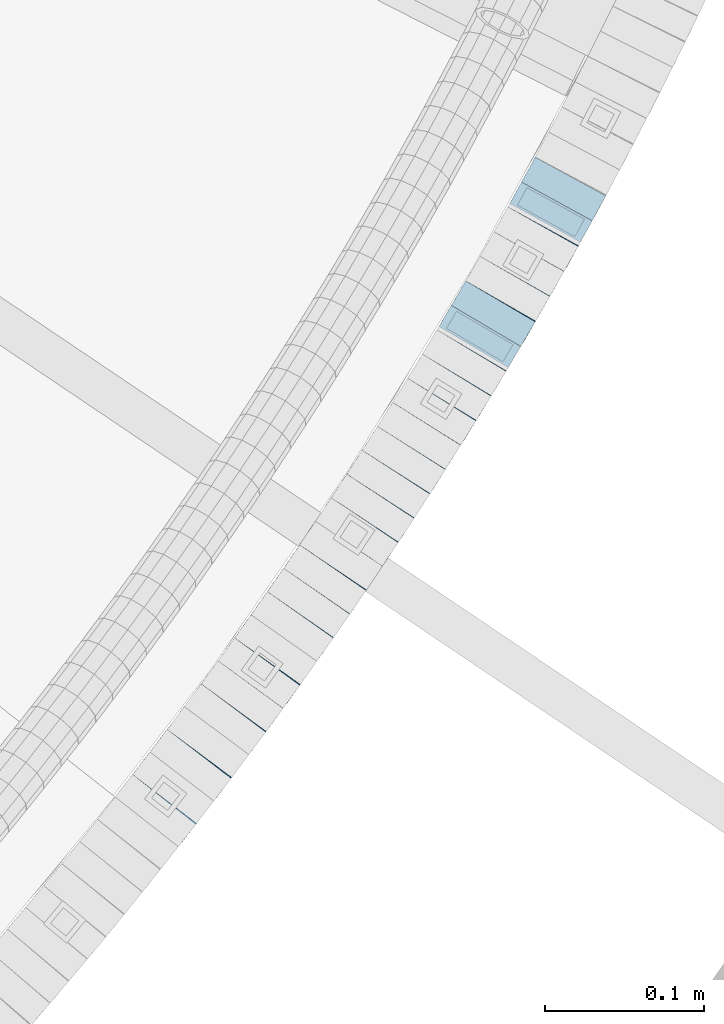
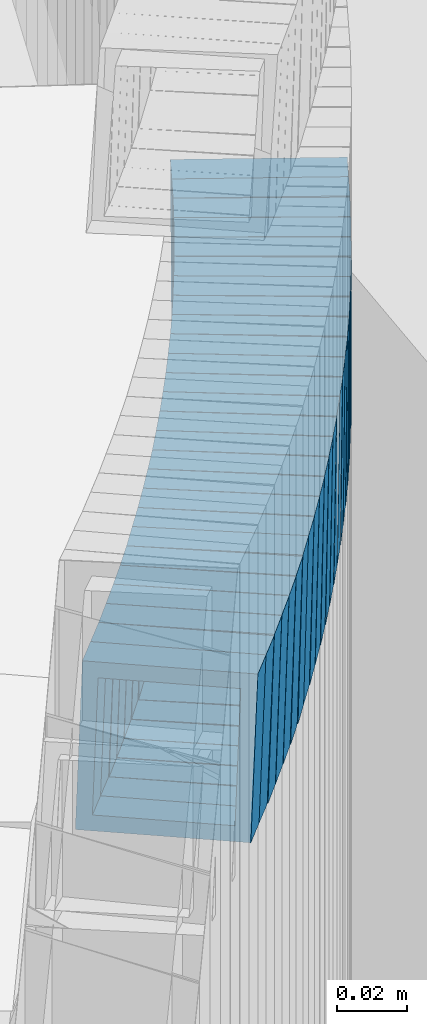
# One storey, part 778 of 975: 26 beams.
"""IFC2X3 building model written with IfcOpenShell, lengths in millimetres."""

from ifc_helpers import new_model, si_unit, frame, origin_with_axes, place, context, subcontext, project, spatial, faceted_brep, material, type_object, element, save


model = new_model("IFC2X3")

# Units and contexts
model_context = context("Model", 3, precision=1e-05, world=origin_with_axes())
body_context = subcontext(model_context, "Body", "Model", "MODEL_VIEW")
ifc_project = project(units=[si_unit("LENGTHUNIT", "METRE", prefix="MILLI"), si_unit("AREAUNIT", "SQUARE_METRE"), si_unit("VOLUMEUNIT", "CUBIC_METRE"), si_unit("MASSUNIT", "GRAM", prefix="KILO"), si_unit("TIMEUNIT", "SECOND"), si_unit("PLANEANGLEUNIT", "RADIAN"), si_unit("SOLIDANGLEUNIT", "STERADIAN"), si_unit("THERMODYNAMICTEMPERATUREUNIT", "DEGREE_CELSIUS"), si_unit("LUMINOUSINTENSITYUNIT", "LUMEN")], contexts=[model_context])

# Site, building, storey
site_placement = place(None, origin_with_axes())
site = spatial("IfcSite", under=ifc_project, at=site_placement, CompositionType="ELEMENT")
building_placement = place(site_placement, origin_with_axes())
building = spatial("IfcBuilding", under=site, at=building_placement, Name="Undefined", CompositionType="ELEMENT")
storey_placement = place(building_placement, origin_with_axes())
storey = spatial("IfcBuildingStorey", under=building, at=storey_placement, Name="Undefined", CompositionType="ELEMENT", Elevation=0.0)

# Beams
ifc_material = material()
beam_type = type_object("IfcBeamType", Name="HSS2X2X.188_TUBES", PredefinedType="NOTDEFINED")
for number, where, z_axis, x_axis, name in (
    (1, (36998.4211909885, 1638.69468786156, 2459.19732250594), (-0.793246576330857, 0.608900541253967, 0.0), (0.58019777288617, 0.755853978851687, -0.303406174940462), "WALL"),
    (2, (37009.3211909885, 1652.89468786156, 2453.49732250594), (-0.793246576330857, 0.608900541253967, 0.0), (0.58019777288617, 0.755853978851687, -0.303406174940462), "WALL"),
):
    element("IfcBeam", number, at=place(storey_placement, frame(where, z_axis=z_axis, x_axis=x_axis)), inside=storey, type_object=beam_type, material=ifc_material, Name=name, ObjectType="HSS2X2X.188_TUBES", context=body_context, shape_type="Brep", body=[
        faceted_brep([(0.0, 20.6374999999753, -20.6375000000298), (0.0, -20.6375000000153, -20.6375000000153), (18.7853666454903, -20.6375000000535, -20.6375000000326), (18.785366645363, 20.6374999999862, -20.6375000000044), (0.0, -20.6374999999825, 20.6375000000335), (18.785366645352, -20.6375000000007, 20.6374999999989), (0.0, 20.6375000000116, 20.6375000000189), (18.7853666453102, 20.6375000000025, 20.6374999999753), (0.0, 25.3999999999724, -25.4000000000342), (0.0, 25.400000000016, 25.4000000000196), (18.7853666452065, 25.4000000000451, 25.4000000000351), (18.7853666453739, 25.3999999999833, -25.400000000006), (0.0, -25.399999999976, 25.4000000000378), (18.7853666497213, -25.399999993424, 25.3999999995158), (0.0, -25.400000000016, -25.4000000000196), (18.7853666455194, -25.4000000000633, -25.4000000000406)], [[[0, 1, 2, 3]], [[1, 4, 5, 2]], [[4, 6, 7, 5]], [[6, 0, 3, 7]], [[8, 9, 10, 11]], [[9, 12, 13, 10]], [[12, 14, 15, 13]], [[14, 8, 11, 15]], [[13, 15, 11, 10], [5, 7, 3, 2]], [[14, 12, 9, 8], [6, 4, 1, 0]]]),
    ])
beam_1_placement = place(storey_placement, frame((37020.4021489882, 1667.17520577489, 2447.84194460413), z_axis=(-0.800671390520529, 0.599103767641235, 0.0), x_axis=(0.569810315255925, 0.76152219734206, -0.308869143138749)))
element("IfcBeam", 3, at=beam_1_placement, inside=storey, type_object=beam_type, material=ifc_material, Name="WALL", ObjectType="HSS2X2X.188_TUBES", context=body_context, shape_type="Brep", body=[
    faceted_brep([(0.0, 20.6374999999753, -20.6375000000298), (0.0, -20.6375000000153, -20.6375000000153), (18.7771137292038, -20.637500000008, -20.6374999999862), (18.777113729182, 20.6375000000062, -20.6375000000189), (0.0, -20.6374999999825, 20.6375000000335), (18.7771137291729, -20.6374999999916, 20.6374999999753), (0.0, 20.6375000000116, 20.6375000000189), (18.7771137291529, 20.6375000000207, 20.6374999999389), (0.0, 25.3999999999724, -25.4000000000342), (0.0, 25.400000000016, 25.4000000000196), (18.7771137291475, 25.4000000000251, 25.3999999999287), (18.7771137291857, 25.4000000000051, -25.4000000000196), (0.0, -25.399999999976, 25.4000000000378), (18.7771137291711, -25.3999999999905, 25.3999999999724), (0.0, -25.400000000016, -25.4000000000196), (18.7771137292129, -25.4000000000124, -25.3999999999724)], [[[0, 1, 2, 3]], [[1, 4, 5, 2]], [[4, 6, 7, 5]], [[6, 0, 3, 7]], [[8, 9, 10, 11]], [[9, 12, 13, 10]], [[12, 14, 15, 13]], [[14, 8, 11, 15]], [[13, 15, 11, 10], [5, 7, 3, 2]], [[14, 12, 9, 8], [6, 4, 1, 0]]]),
])
beam_2_placement = place(storey_placement, frame((37031.2657047011, 1681.65115418061, 2441.99247534744), z_axis=(-0.802667604861859, 0.596426622565866, 8.45366230350917e-11), x_axis=(0.568425676172404, 0.764984088232071, -0.302806201091873)))
element("IfcBeam", 4, at=beam_2_placement, inside=storey, type_object=beam_type, material=ifc_material, Name="WALL", ObjectType="HSS2X2X.188_TUBES", context=body_context, shape_type="Brep", body=[
    faceted_brep([(0.0, 20.6374999999753, -20.6375000000298), (0.0, -20.6375000000153, -20.6375000000153), (18.8225928075335, -20.6374999999935, -20.6375000000298), (18.8225928075699, 20.6374999999898, -20.6374999999825), (0.0, -20.6374999999825, 20.6375000000335), (18.8225928075772, -20.637500000008, 20.6375000000226), (0.0, 20.6375000000116, 20.6375000000189), (18.8225928076135, 20.6374999999753, 20.6375000000698), (0.0, 25.3999999999724, -25.4000000000342), (0.0, 25.400000000016, 25.4000000000196), (18.8225928076281, 25.3999999999705, 25.4000000000815), (18.8225928075663, 25.3999999999905, -25.3999999999796), (0.0, -25.399999999976, 25.4000000000378), (18.8225928075808, -25.4000000000087, 25.4000000000233), (0.0, -25.400000000016, -25.4000000000196), (18.8225928075226, -25.3999999999905, -25.4000000000378)], [[[0, 1, 2, 3]], [[1, 4, 5, 2]], [[4, 6, 7, 5]], [[6, 0, 3, 7]], [[8, 9, 10, 11]], [[9, 12, 13, 10]], [[12, 14, 15, 13]], [[14, 8, 11, 15]], [[13, 15, 11, 10], [5, 7, 3, 2]], [[14, 12, 9, 8], [6, 4, 1, 0]]]),
])
beam_3_placement = place(storey_placement, frame((37041.9748429685, 1696.00489578929, 2436.33927704001), z_axis=(-0.805336884132331, 0.592817428097411, 0.0), x_axis=(0.563893608736479, 0.766044147641969, -0.308545558855802)))
element("IfcBeam", 5, at=beam_3_placement, inside=storey, type_object=beam_type, material=ifc_material, Name="WALL", ObjectType="HSS2X2X.188_TUBES", context=body_context, shape_type="Brep", body=[
    faceted_brep([(0.0, 20.6374999999753, -20.6375000000298), (0.0, -20.6375000000153, -20.6375000000153), (18.8047866246379, -20.6374999999916, -20.6375000000298), (18.8047866247143, 20.6374999999844, -20.6374999999643), (0.0, -20.6374999999825, 20.6375000000335), (18.8047866247107, -20.6375000000189, 20.6375000000407), (0.0, 20.6375000000116, 20.6375000000189), (18.8047866247907, 20.6374999999589, 20.6375000001026), (0.0, 25.3999999999724, -25.4000000000342), (0.0, 25.400000000016, 25.4000000000196), (18.8047866248016, 25.3999999999542, 25.4000000001142), (18.8047866247143, 25.3999999999851, -25.3999999999651), (0.0, -25.399999999976, 25.4000000000378), (18.8047866247107, -25.4000000000196, 25.4000000000415), (0.0, -25.400000000016, -25.4000000000196), (18.8047866246197, -25.3999999999887, -25.4000000000378)], [[[0, 1, 2, 3]], [[1, 4, 5, 2]], [[4, 6, 7, 5]], [[6, 0, 3, 7]], [[8, 9, 10, 11]], [[9, 12, 13, 10]], [[12, 14, 15, 13]], [[14, 8, 11, 15]], [[13, 15, 11, 10], [5, 7, 3, 2]], [[14, 12, 9, 8], [6, 4, 1, 0]]]),
])
beam_4_placement = place(storey_placement, frame((37052.8181324932, 1710.63518996149, 2430.4971487143), z_axis=(-0.80994212177235, 0.58650981183515, 0.0), x_axis=(0.558866525994781, 0.771768059992731, -0.303384685997138)))
element("IfcBeam", 6, at=beam_4_placement, inside=storey, type_object=beam_type, material=ifc_material, Name="WALL", ObjectType="HSS2X2X.188_TUBES", context=body_context, shape_type="Brep", body=[
    faceted_brep([(0.0, 20.6374999999753, -20.6375000000298), (0.0, -20.6375000000153, -20.6375000000153), (18.7853666454903, -20.6375000000535, -20.6375000000326), (18.785366645363, 20.6374999999862, -20.6375000000044), (0.0, -20.6374999999825, 20.6375000000335), (18.785366645352, -20.6375000000007, 20.6374999999989), (0.0, 20.6375000000116, 20.6375000000189), (18.7853666453102, 20.6375000000025, 20.6374999999753), (0.0, 25.3999999999724, -25.4000000000342), (0.0, 25.400000000016, 25.4000000000196), (18.7853666452065, 25.4000000000451, 25.4000000000351), (18.7853666453739, 25.3999999999833, -25.400000000006), (0.0, -25.399999999976, 25.4000000000378), (18.7853666497213, -25.399999993424, 25.3999999995158), (0.0, -25.400000000016, -25.4000000000196), (18.7853666455194, -25.4000000000633, -25.4000000000406)], [[[0, 1, 2, 3]], [[1, 4, 5, 2]], [[4, 6, 7, 5]], [[6, 0, 3, 7]], [[8, 9, 10, 11]], [[9, 12, 13, 10]], [[12, 14, 15, 13]], [[14, 8, 11, 15]], [[13, 15, 11, 10], [5, 7, 3, 2]], [[14, 12, 9, 8], [6, 4, 1, 0]]]),
])
beam_5_placement = place(storey_placement, frame((37063.5700560155, 1725.32385394075, 2424.80150870524), z_axis=(-0.817122939119162, 0.576463444084065, 0.0), x_axis=(0.549194709889691, 0.778470170843594, -0.303923285938943)))
element("IfcBeam", 7, at=beam_5_placement, inside=storey, type_object=beam_type, material=ifc_material, Name="WALL", ObjectType="HSS2X2X.188_TUBES", context=body_context, shape_type="Brep", body=[
    faceted_brep([(0.0, 20.6374999999753, -20.6375000000298), (0.0, -20.6375000000153, -20.6375000000153), (18.7547327359644, -20.6374999999844, -20.6375000000553), (18.7547327359898, 20.6375000000171, -20.6375000000335), (0.0, -20.6374999999825, 20.6375000000335), (18.7547327360044, -20.6374999999953, 20.6374999999898), (0.0, 20.6375000000116, 20.6375000000189), (18.7547327360262, 20.6375000000062, 20.6375000000116), (0.0, 25.3999999999724, -25.4000000000342), (0.0, 25.400000000016, 25.4000000000196), (18.7547327360371, 25.4000000000033, 25.4000000000124), (18.7547327359898, 25.4000000000178, -25.4000000000342), (0.0, -25.399999999976, 25.4000000000378), (18.7547327360044, -25.399999999996, 25.3999999999869), (0.0, -25.400000000016, -25.4000000000196), (18.7547327359498, -25.3999999999814, -25.4000000000597)], [[[0, 1, 2, 3]], [[1, 4, 5, 2]], [[4, 6, 7, 5]], [[6, 0, 3, 7]], [[8, 9, 10, 11]], [[9, 12, 13, 10]], [[12, 14, 15, 13]], [[14, 8, 11, 15]], [[13, 15, 11, 10], [5, 7, 3, 2]], [[14, 12, 9, 8], [6, 4, 1, 0]]]),
])
beam_6_placement = place(storey_placement, frame((37073.799368373, 1739.82365592313, 2419.14096997326), z_axis=(-0.817122939119162, 0.576463444084065, 0.0), x_axis=(0.548299120091754, 0.777200694130078, -0.308750961051676)))
element("IfcBeam", 8, at=beam_6_placement, inside=storey, type_object=beam_type, material=ifc_material, Name="WALL", ObjectType="HSS2X2X.188_TUBES", context=body_context, shape_type="Brep", body=[
    faceted_brep([(0.0, 20.6374999999753, -20.6375000000298), (0.0, -20.6375000000153, -20.6375000000153), (18.7853666454903, -20.6375000000535, -20.6375000000326), (18.785366645363, 20.6374999999862, -20.6375000000044), (0.0, -20.6374999999825, 20.6375000000335), (18.785366645352, -20.6375000000007, 20.6374999999989), (0.0, 20.6375000000116, 20.6375000000189), (18.7853666453102, 20.6375000000025, 20.6374999999753), (0.0, 25.3999999999724, -25.4000000000342), (0.0, 25.400000000016, 25.4000000000196), (18.7853666452065, 25.4000000000451, 25.4000000000351), (18.7853666453739, 25.3999999999833, -25.400000000006), (0.0, -25.399999999976, 25.4000000000378), (18.7853666497213, -25.399999993424, 25.3999999995158), (0.0, -25.400000000016, -25.4000000000196), (18.7853666455194, -25.4000000000633, -25.4000000000406)], [[[0, 1, 2, 3]], [[1, 4, 5, 2]], [[4, 6, 7, 5]], [[6, 0, 3, 7]], [[8, 9, 10, 11]], [[9, 12, 13, 10]], [[12, 14, 15, 13]], [[14, 8, 11, 15]], [[13, 15, 11, 10], [5, 7, 3, 2]], [[14, 12, 9, 8], [6, 4, 1, 0]]]),
])
beam_7_placement = place(storey_placement, frame((37084.3382322431, 1754.65940346725, 2413.29843596918), z_axis=(-0.821588113820831, 0.570081547875679, 0.0), x_axis=(0.543183665244015, 0.782823517351603, -0.30354381313633)))
element("IfcBeam", 9, at=beam_7_placement, inside=storey, type_object=beam_type, material=ifc_material, Name="WALL", ObjectType="HSS2X2X.188_TUBES", context=body_context, shape_type="Brep", body=[
    faceted_brep([(0.0, 20.6374999999753, -20.6375000000298), (0.0, -20.6375000000153, -20.6375000000153), (18.7771137292038, -20.637500000008, -20.6374999999862), (18.777113729182, 20.6375000000062, -20.6375000000189), (0.0, -20.6374999999825, 20.6375000000335), (18.7771137291729, -20.6374999999916, 20.6374999999753), (0.0, 20.6375000000116, 20.6375000000189), (18.7771137291529, 20.6375000000207, 20.6374999999389), (0.0, 25.3999999999724, -25.4000000000342), (0.0, 25.400000000016, 25.4000000000196), (18.7771137291475, 25.4000000000251, 25.3999999999287), (18.7771137291857, 25.4000000000051, -25.4000000000196), (0.0, -25.399999999976, 25.4000000000378), (18.7771137291711, -25.3999999999905, 25.3999999999724), (0.0, -25.400000000016, -25.4000000000196), (18.7771137292129, -25.4000000000124, -25.3999999999724)], [[[0, 1, 2, 3]], [[1, 4, 5, 2]], [[4, 6, 7, 5]], [[6, 0, 3, 7]], [[8, 9, 10, 11]], [[9, 12, 13, 10]], [[12, 14, 15, 13]], [[14, 8, 11, 15]], [[13, 15, 11, 10], [5, 7, 3, 2]], [[14, 12, 9, 8], [6, 4, 1, 0]]]),
])
beam_8_placement = place(storey_placement, frame((37094.6213176872, 1769.41713653642, 2407.60554805691), z_axis=(-0.824205484572543, 0.566290843295686, -1.55247107613832e-10), x_axis=(0.539413251956117, 0.785086613936193, -0.304421339975255)))
element("IfcBeam", 10, at=beam_8_placement, inside=storey, type_object=beam_type, material=ifc_material, Name="WALL", ObjectType="HSS2X2X.188_TUBES", context=body_context, shape_type="Brep", body=[
    faceted_brep([(0.0, 20.6374999999753, -20.6375000000298), (0.0, -20.6375000000153, -20.6375000000153), (18.724849799155, -20.6375000000171, -20.6374999999425), (18.7248497991204, 20.6374999999989, -20.6375000000007), (0.0, -20.6374999999825, 20.6375000000335), (18.7248497991168, -20.6374999999953, 20.6375000000007), (0.0, 20.6375000000116, 20.6375000000189), (18.724849799084, 20.6375000000226, 20.6374999999498), (0.0, 25.3999999999724, -25.4000000000342), (0.0, 25.400000000016, 25.4000000000196), (18.7248497990731, 25.4000000000269, 25.399999999936), (18.7248497991204, 25.3999999999978, -25.3999999999978), (0.0, -25.399999999976, 25.4000000000378), (18.7248497991186, -25.3999999999942, 25.4000000000051), (0.0, -25.400000000016, -25.4000000000196), (18.7248497991604, -25.4000000000233, -25.3999999999323)], [[[0, 1, 2, 3]], [[1, 4, 5, 2]], [[4, 6, 7, 5]], [[6, 0, 3, 7]], [[8, 9, 10, 11]], [[9, 12, 13, 10]], [[12, 14, 15, 13]], [[14, 8, 11, 15]], [[13, 15, 11, 10], [5, 7, 3, 2]], [[14, 12, 9, 8], [6, 4, 1, 0]]]),
])
for number, where, z_axis, x_axis, name in (
    (11, (37104.8195276145, 1784.1535950912, 2401.94172788713), (-0.828588968736746, 0.559857411210905, -1.04603259387659e-10), (0.532487704189936, 0.788081802280939, -0.308842869110098), "WALL"),
    (12, (37115.0536660149, 1799.19458440245, 2396.0988192009), (-0.832909293479453, 0.553409530849948, -5.19667082699015e-11), (0.52728992590597, 0.793597968858397, -0.303591168945843), "WALL"),
):
    element("IfcBeam", number, at=place(storey_placement, frame(where, z_axis=z_axis, x_axis=x_axis)), inside=storey, type_object=beam_type, material=ifc_material, Name=name, ObjectType="HSS2X2X.188_TUBES", context=body_context, shape_type="Brep", body=[
        faceted_brep([(0.0, 20.6374999999753, -20.6375000000298), (0.0, -20.6375000000153, -20.6375000000153), (18.7771137292038, -20.637500000008, -20.6374999999862), (18.777113729182, 20.6375000000062, -20.6375000000189), (0.0, -20.6374999999825, 20.6375000000335), (18.7771137291729, -20.6374999999916, 20.6374999999753), (0.0, 20.6375000000116, 20.6375000000189), (18.7771137291529, 20.6375000000207, 20.6374999999389), (0.0, 25.3999999999724, -25.4000000000342), (0.0, 25.400000000016, 25.4000000000196), (18.7771137291475, 25.4000000000251, 25.3999999999287), (18.7771137291857, 25.4000000000051, -25.4000000000196), (0.0, -25.399999999976, 25.4000000000378), (18.7771137291711, -25.3999999999905, 25.3999999999724), (0.0, -25.400000000016, -25.4000000000196), (18.7771137292129, -25.4000000000124, -25.3999999999724)], [[[0, 1, 2, 3]], [[1, 4, 5, 2]], [[4, 6, 7, 5]], [[6, 0, 3, 7]], [[8, 9, 10, 11]], [[9, 12, 13, 10]], [[12, 14, 15, 13]], [[14, 8, 11, 15]], [[13, 15, 11, 10], [5, 7, 3, 2]], [[14, 12, 9, 8], [6, 4, 1, 0]]]),
    ])
beam_9_placement = place(storey_placement, frame((37125.0372374147, 1814.15560473206, 2390.40572429746), z_axis=(-0.835484829267466, 0.549513512175918, 0.0), x_axis=(0.523428401875718, 0.795824815810967, -0.304443049927688)))
element("IfcBeam", 13, at=beam_9_placement, inside=storey, type_object=beam_type, material=ifc_material, Name="WALL", ObjectType="HSS2X2X.188_TUBES", context=body_context, shape_type="Brep", body=[
    faceted_brep([(0.0, 20.6374999999753, -20.6375000000298), (0.0, -20.6375000000153, -20.6375000000153), (18.724849799155, -20.6375000000171, -20.6374999999425), (18.7248497991204, 20.6374999999989, -20.6375000000007), (0.0, -20.6374999999825, 20.6375000000335), (18.7248497991168, -20.6374999999953, 20.6375000000007), (0.0, 20.6375000000116, 20.6375000000189), (18.724849799084, 20.6375000000226, 20.6374999999498), (0.0, 25.3999999999724, -25.4000000000342), (0.0, 25.400000000016, 25.4000000000196), (18.7248497990731, 25.4000000000269, 25.399999999936), (18.7248497991204, 25.3999999999978, -25.3999999999978), (0.0, -25.399999999976, 25.4000000000378), (18.7248497991186, -25.3999999999942, 25.4000000000051), (0.0, -25.400000000016, -25.4000000000196), (18.7248497991604, -25.4000000000233, -25.3999999999323)], [[[0, 1, 2, 3]], [[1, 4, 5, 2]], [[4, 6, 7, 5]], [[6, 0, 3, 7]], [[8, 9, 10, 11]], [[9, 12, 13, 10]], [[12, 14, 15, 13]], [[14, 8, 11, 15]], [[13, 15, 11, 10], [5, 7, 3, 2]], [[14, 12, 9, 8], [6, 4, 1, 0]]]),
])
beam_10_placement = place(storey_placement, frame((37135.0012540863, 1829.19742051595, 2384.70206907921), z_axis=(-0.83972031877, 0.543019139851267, 0.0), x_axis=(0.517320457847144, 0.799980089763606, -0.303992433910178)))
element("IfcBeam", 14, at=beam_10_placement, inside=storey, type_object=beam_type, material=ifc_material, Name="WALL", ObjectType="HSS2X2X.188_TUBES", context=body_context, shape_type="Brep", body=[
    faceted_brep([(0.0, 20.6374999999753, -20.6375000000298), (0.0, -20.6375000000153, -20.6375000000153), (18.7547327359644, -20.6374999999844, -20.6375000000553), (18.7547327359898, 20.6375000000171, -20.6375000000335), (0.0, -20.6374999999825, 20.6375000000335), (18.7547327360044, -20.6374999999953, 20.6374999999898), (0.0, 20.6375000000116, 20.6375000000189), (18.7547327360262, 20.6375000000062, 20.6375000000116), (0.0, 25.3999999999724, -25.4000000000342), (0.0, 25.400000000016, 25.4000000000196), (18.7547327360371, 25.4000000000033, 25.4000000000124), (18.7547327359898, 25.4000000000178, -25.4000000000342), (0.0, -25.399999999976, 25.4000000000378), (18.7547327360044, -25.399999999996, 25.3999999999869), (0.0, -25.400000000016, -25.4000000000196), (18.7547327359498, -25.3999999999814, -25.4000000000597)], [[[0, 1, 2, 3]], [[1, 4, 5, 2]], [[4, 6, 7, 5]], [[6, 0, 3, 7]], [[8, 9, 10, 11]], [[9, 12, 13, 10]], [[12, 14, 15, 13]], [[14, 8, 11, 15]], [[13, 15, 11, 10], [5, 7, 3, 2]], [[14, 12, 9, 8], [6, 4, 1, 0]]]),
])
for number, where, z_axis, x_axis, name in (
    (15, (37144.7189424457, 1844.15699495478, 2379.04855451696), (-0.842271400952091, 0.539053695969337, 0.0), (0.512556140205517, 0.800868969321066, -0.309669335124153), "WALL"),
    (16, (37154.5476637936, 1859.40474376043, 2373.20498443343), (-0.846420002588977, 0.53251589574141, 0.0), (0.507253164941176, 0.806265556906497, -0.304351898964696), "WALL"),
):
    element("IfcBeam", number, at=place(storey_placement, frame(where, z_axis=z_axis, x_axis=x_axis)), inside=storey, type_object=beam_type, material=ifc_material, Name=name, ObjectType="HSS2X2X.188_TUBES", context=body_context, shape_type="Brep", body=[
        faceted_brep([(0.0, 20.6374999999753, -20.6375000000298), (0.0, -20.6375000000153, -20.6375000000153), (18.7347271129966, -20.6375000000116, -20.6375000000262), (18.7347271130257, 20.6374999999989, -20.6374999999935), (0.0, -20.6374999999825, 20.6375000000335), (18.7347271129947, -20.6375000000116, 20.6374999999607), (0.0, 20.6375000000116, 20.6375000000189), (18.7347271130147, 20.6375000000007, 20.6374999999898), (0.0, 25.3999999999724, -25.4000000000342), (0.0, 25.400000000016, 25.4000000000196), (18.7347271130166, 25.4000000000015, 25.3999999999905), (18.7347271130257, 25.3999999999996, -25.3999999999869), (0.0, -25.399999999976, 25.4000000000378), (18.7347271129875, -25.4000000000106, 25.3999999999505), (0.0, -25.400000000016, -25.4000000000196), (18.7347271130002, -25.4000000000124, -25.4000000000233)], [[[0, 1, 2, 3]], [[1, 4, 5, 2]], [[4, 6, 7, 5]], [[6, 0, 3, 7]], [[8, 9, 10, 11]], [[9, 12, 13, 10]], [[12, 14, 15, 13]], [[14, 8, 11, 15]], [[13, 15, 11, 10], [5, 7, 3, 2]], [[14, 12, 9, 8], [6, 4, 1, 0]]]),
    ])
beam_11_placement = place(storey_placement, frame((37164.1247932332, 1874.5846063753, 2367.4944094909), z_axis=(-0.847998304219242, 0.529998939660534, 1.28492501971778e-10), x_axis=(0.505076271980184, 0.808122035968303, -0.303045762988108)))
element("IfcBeam", 17, at=beam_11_placement, inside=storey, type_object=beam_type, material=ifc_material, Name="WALL", ObjectType="HSS2X2X.188_TUBES", context=body_context, shape_type="Brep", body=[
    faceted_brep([(0.0, 20.6374999999753, -20.6375000000298), (0.0, -20.6375000000153, -20.6375000000153), (18.8066477608099, -20.6374999999862, -20.6375000000116), (18.8066477608172, 20.6375000000062, -20.6374999999971), (0.0, -20.6374999999825, 20.6375000000335), (18.8066477608463, -20.6375000000062, 20.6375000000407), (0.0, 20.6375000000116, 20.6375000000189), (18.8066477608536, 20.6374999999844, 20.637500000048), (0.0, 25.3999999999724, -25.4000000000342), (0.0, 25.400000000016, 25.4000000000196), (18.8066477608591, 25.3999999999814, 25.400000000056), (18.8066477608154, 25.4000000000051, -25.4000000000015), (0.0, -25.399999999976, 25.4000000000378), (18.8066477608518, -25.4000000000087, 25.4000000000451), (0.0, -25.400000000016, -25.4000000000196), (18.8066477608081, -25.3999999999851, -25.4000000000196)], [[[0, 1, 2, 3]], [[1, 4, 5, 2]], [[4, 6, 7, 5]], [[6, 0, 3, 7]], [[8, 9, 10, 11]], [[9, 12, 13, 10]], [[12, 14, 15, 13]], [[14, 8, 11, 15]], [[13, 15, 11, 10], [5, 7, 3, 2]], [[14, 12, 9, 8], [6, 4, 1, 0]]]),
])
beam_12_placement = place(storey_placement, frame((37173.7927353699, 1889.91651493569, 2361.80756026037), z_axis=(-0.853004271925895, 0.521903929929804, 6.78255673847163e-12), x_axis=(0.497091707841003, 0.812450962740235, -0.304669110902598)))
element("IfcBeam", 18, at=beam_12_placement, inside=storey, type_object=beam_type, material=ifc_material, Name="WALL", ObjectType="HSS2X2X.188_TUBES", context=body_context, shape_type="Brep", body=[
    faceted_brep([(0.0, 20.6374999999753, -20.6375000000298), (0.0, -20.6375000000153, -20.6375000000153), (18.7112265765609, -20.6375000000062, -20.6374999999862), (18.7112265765645, 20.6374999999898, -20.6374999999789), (0.0, -20.6374999999825, 20.6375000000335), (18.7112265765209, -20.6374999999916, 20.6374999999607), (0.0, 20.6375000000116, 20.6375000000189), (18.7112265765245, 20.6375000000025, 20.6374999999716), (0.0, 25.3999999999724, -25.4000000000342), (0.0, 25.400000000016, 25.4000000000196), (18.7112265765172, 25.4000000000051, 25.3999999999614), (18.7112265765718, 25.3999999999887, -25.3999999999724), (0.0, -25.399999999976, 25.4000000000378), (18.7112265765136, -25.3999999999905, 25.3999999999542), (0.0, -25.400000000016, -25.4000000000196), (18.7112265765682, -25.4000000000069, -25.3999999999796)], [[[0, 1, 2, 3]], [[1, 4, 5, 2]], [[4, 6, 7, 5]], [[6, 0, 3, 7]], [[8, 9, 10, 11]], [[9, 12, 13, 10]], [[12, 14, 15, 13]], [[14, 8, 11, 15]], [[13, 15, 11, 10], [5, 7, 3, 2]], [[14, 12, 9, 8], [6, 4, 1, 0]]]),
])
for number, where, z_axis, x_axis, name in (
    (19, (37183.1887313206, 1905.15904804162, 2356.142848407), (-0.8569982982223, 0.515319237797389, 9.36265678319613e-11), (0.490104131877153, 0.8150644807957, -0.308978691922563), "WALL"),
    (20, (37192.6095643333, 1920.71294414075, 2350.29899347823), (-0.860926528214316, 0.508729312126641, 0.0), (0.484715016026174, 0.820286950044337, -0.303612702016409), "WALL"),
    (21, (37201.7095643333, 1936.11294414074, 2344.59899347823), (-0.860926528214316, 0.508729312126641, 0.0), (0.484715016026174, 0.820286950044337, -0.303612702016409), "WALL"),
):
    element("IfcBeam", number, at=place(storey_placement, frame(where, z_axis=z_axis, x_axis=x_axis)), inside=storey, type_object=beam_type, material=ifc_material, Name=name, ObjectType="HSS2X2X.188_TUBES", context=body_context, shape_type="Brep", body=[
        faceted_brep([(0.0, 20.6374999999753, -20.6375000000298), (0.0, -20.6375000000153, -20.6375000000153), (18.767258723612, -20.6375000000025, -20.6374999999862), (18.7672587236229, 20.6374999999953, -20.637499999968), (0.0, -20.6374999999825, 20.6375000000335), (18.767258723612, -20.6375000000135, 20.6375000000153), (0.0, 20.6375000000116, 20.6375000000189), (18.7672587236266, 20.6374999999844, 20.6375000000371), (0.0, 25.3999999999724, -25.4000000000342), (0.0, 25.400000000016, 25.4000000000196), (18.7672587236302, 25.3999999999814, 25.4000000000342), (18.7672587236229, 25.399999999996, -25.3999999999687), (0.0, -25.399999999976, 25.4000000000378), (18.7672587236157, -25.4000000000142, 25.400000000016), (0.0, -25.400000000016, -25.4000000000196), (18.767258723612, -25.4000000000015, -25.3999999999905)], [[[0, 1, 2, 3]], [[1, 4, 5, 2]], [[4, 6, 7, 5]], [[6, 0, 3, 7]], [[8, 9, 10, 11]], [[9, 12, 13, 10]], [[12, 14, 15, 13]], [[14, 8, 11, 15]], [[13, 15, 11, 10], [5, 7, 3, 2]], [[14, 12, 9, 8], [6, 4, 1, 0]]]),
    ])
beam_13_placement = place(storey_placement, frame((37210.9884590801, 1951.62725218057, 2338.94021298464), z_axis=(-0.867208357151329, 0.497945444086893, 0.0), x_axis=(0.473632120903856, 0.824864929832649, -0.308659134937384)))
element("IfcBeam", 22, at=beam_13_placement, inside=storey, type_object=beam_type, material=ifc_material, Name="WALL", ObjectType="HSS2X2X.188_TUBES", context=body_context, shape_type="Brep", body=[
    faceted_brep([(0.0, 20.6374999999753, -20.6375000000298), (0.0, -20.6375000000153, -20.6375000000153), (18.7853666454903, -20.6375000000535, -20.6375000000326), (18.785366645363, 20.6374999999862, -20.6375000000044), (0.0, -20.6374999999825, 20.6375000000335), (18.785366645352, -20.6375000000007, 20.6374999999989), (0.0, 20.6375000000116, 20.6375000000189), (18.7853666453102, 20.6375000000025, 20.6374999999753), (0.0, 25.3999999999724, -25.4000000000342), (0.0, 25.400000000016, 25.4000000000196), (18.7853666452065, 25.4000000000451, 25.4000000000351), (18.7853666453739, 25.3999999999833, -25.400000000006), (0.0, -25.399999999976, 25.4000000000378), (18.7853666497213, -25.399999993424, 25.3999999995158), (0.0, -25.400000000016, -25.4000000000196), (18.7853666455194, -25.4000000000633, -25.4000000000406)], [[[0, 1, 2, 3]], [[1, 4, 5, 2]], [[4, 6, 7, 5]], [[6, 0, 3, 7]], [[8, 9, 10, 11]], [[9, 12, 13, 10]], [[12, 14, 15, 13]], [[14, 8, 11, 15]], [[13, 15, 11, 10], [5, 7, 3, 2]], [[14, 12, 9, 8], [6, 4, 1, 0]]]),
])
beam_14_placement = place(storey_placement, frame((37220.0337709371, 1967.30533045976, 2333.1069947531), z_axis=(-0.869620813888935, 0.493720204216059, -7.76221895648633e-11), x_axis=(0.470258877823149, 0.828296886688599, -0.304599499885483)))
element("IfcBeam", 23, at=beam_14_placement, inside=storey, type_object=beam_type, material=ifc_material, Name="WALL", ObjectType="HSS2X2X.188_TUBES", context=body_context, shape_type="Brep", body=[
    faceted_brep([(0.0, 20.6374999999753, -20.6375000000298), (0.0, -20.6375000000153, -20.6375000000153), (18.7112265765609, -20.6375000000062, -20.6374999999862), (18.7112265765645, 20.6374999999898, -20.6374999999789), (0.0, -20.6374999999825, 20.6375000000335), (18.7112265765209, -20.6374999999916, 20.6374999999607), (0.0, 20.6375000000116, 20.6375000000189), (18.7112265765245, 20.6375000000025, 20.6374999999716), (0.0, 25.3999999999724, -25.4000000000342), (0.0, 25.400000000016, 25.4000000000196), (18.7112265765172, 25.4000000000051, 25.3999999999614), (18.7112265765718, 25.3999999999887, -25.3999999999724), (0.0, -25.399999999976, 25.4000000000378), (18.7112265765136, -25.3999999999905, 25.3999999999542), (0.0, -25.400000000016, -25.4000000000196), (18.7112265765682, -25.4000000000069, -25.3999999999796)], [[[0, 1, 2, 3]], [[1, 4, 5, 2]], [[4, 6, 7, 5]], [[6, 0, 3, 7]], [[8, 9, 10, 11]], [[9, 12, 13, 10]], [[12, 14, 15, 13]], [[14, 8, 11, 15]], [[13, 15, 11, 10], [5, 7, 3, 2]], [[14, 12, 9, 8], [6, 4, 1, 0]]]),
])
beam_15_placement = place(storey_placement, frame((37228.9035843217, 1982.88548700346, 2327.39610702362), z_axis=(-0.870978467775846, 0.491321186873555, 0.0), x_axis=(0.468184465966097, 0.829963370939768, -0.303255846977989)))
element("IfcBeam", 24, at=beam_15_placement, inside=storey, type_object=beam_type, material=ifc_material, Name="WALL", ObjectType="HSS2X2X.188_TUBES", context=body_context, shape_type="Brep", body=[
    faceted_brep([(0.0, 20.6374999999753, -20.6375000000298), (0.0, -20.6375000000153, -20.6375000000153), (18.8047866246379, -20.6374999999916, -20.6375000000298), (18.8047866247143, 20.6374999999844, -20.6374999999643), (0.0, -20.6374999999825, 20.6375000000335), (18.8047866247107, -20.6375000000189, 20.6375000000407), (0.0, 20.6375000000116, 20.6375000000189), (18.8047866247907, 20.6374999999589, 20.6375000001026), (0.0, 25.3999999999724, -25.4000000000342), (0.0, 25.400000000016, 25.4000000000196), (18.8047866248016, 25.3999999999542, 25.4000000001142), (18.8047866247143, 25.3999999999851, -25.3999999999651), (0.0, -25.399999999976, 25.4000000000378), (18.8047866247107, -25.4000000000196, 25.4000000000415), (0.0, -25.400000000016, -25.4000000000196), (18.8047866246197, -25.3999999999887, -25.4000000000378)], [[[0, 1, 2, 3]], [[1, 4, 5, 2]], [[4, 6, 7, 5]], [[6, 0, 3, 7]], [[8, 9, 10, 11]], [[9, 12, 13, 10]], [[12, 14, 15, 13]], [[14, 8, 11, 15]], [[13, 15, 11, 10], [5, 7, 3, 2]], [[14, 12, 9, 8], [6, 4, 1, 0]]]),
])
beam_16_placement = place(storey_placement, frame((37237.8808800485, 1998.6050138105, 2321.73665673552), z_axis=(-0.877040228897202, 0.480416940683761, 7.38618837203829e-11), x_axis=(0.457026750035152, 0.834339532064065, -0.308227343023657)))
element("IfcBeam", 25, at=beam_16_placement, inside=storey, type_object=beam_type, material=ifc_material, Name="WALL", ObjectType="HSS2X2X.188_TUBES", context=body_context, shape_type="Brep", body=[
    faceted_brep([(0.0, 20.6374999999753, -20.6375000000298), (0.0, -20.6375000000153, -20.6375000000153), (18.8225928075335, -20.6374999999935, -20.6375000000298), (18.8225928075699, 20.6374999999898, -20.6374999999825), (0.0, -20.6374999999825, 20.6375000000335), (18.8225928075772, -20.637500000008, 20.6375000000226), (0.0, 20.6375000000116, 20.6375000000189), (18.8225928076135, 20.6374999999753, 20.6375000000698), (0.0, 25.3999999999724, -25.4000000000342), (0.0, 25.400000000016, 25.4000000000196), (18.8225928076281, 25.3999999999705, 25.4000000000815), (18.8225928075663, 25.3999999999905, -25.3999999999796), (0.0, -25.399999999976, 25.4000000000378), (18.8225928075808, -25.4000000000087, 25.4000000000233), (0.0, -25.400000000016, -25.4000000000196), (18.8225928075226, -25.3999999999905, -25.4000000000378)], [[[0, 1, 2, 3]], [[1, 4, 5, 2]], [[4, 6, 7, 5]], [[6, 0, 3, 7]], [[8, 9, 10, 11]], [[9, 12, 13, 10]], [[12, 14, 15, 13]], [[14, 8, 11, 15]], [[13, 15, 11, 10], [5, 7, 3, 2]], [[14, 12, 9, 8], [6, 4, 1, 0]]]),
])
beam_17_placement = place(storey_placement, frame((37246.5397107905, 2014.4124141186, 2315.89732250594), z_axis=(-0.877040228897202, 0.480416940683761, 7.38618837203829e-11), x_axis=(0.457770720012597, 0.83569770902282, -0.303406175008286)))
element("IfcBeam", 26, at=beam_17_placement, inside=storey, type_object=beam_type, material=ifc_material, Name="WALL", ObjectType="HSS2X2X.188_TUBES", context=body_context, shape_type="Brep", body=[
    faceted_brep([(0.0, 20.6374999999753, -20.6375000000298), (0.0, -20.6375000000153, -20.6375000000153), (18.7853666454903, -20.6375000000535, -20.6375000000326), (18.785366645363, 20.6374999999862, -20.6375000000044), (0.0, -20.6374999999825, 20.6375000000335), (18.785366645352, -20.6375000000007, 20.6374999999989), (0.0, 20.6375000000116, 20.6375000000189), (18.7853666453102, 20.6375000000025, 20.6374999999753), (0.0, 25.3999999999724, -25.4000000000342), (0.0, 25.400000000016, 25.4000000000196), (18.7853666452065, 25.4000000000451, 25.4000000000351), (18.7853666453739, 25.3999999999833, -25.400000000006), (0.0, -25.399999999976, 25.4000000000378), (18.7853666497213, -25.399999993424, 25.3999999995158), (0.0, -25.400000000016, -25.4000000000196), (18.7853666455194, -25.4000000000633, -25.4000000000406)], [[[0, 1, 2, 3]], [[1, 4, 5, 2]], [[4, 6, 7, 5]], [[6, 0, 3, 7]], [[8, 9, 10, 11]], [[9, 12, 13, 10]], [[12, 14, 15, 13]], [[14, 8, 11, 15]], [[13, 15, 11, 10], [5, 7, 3, 2]], [[14, 12, 9, 8], [6, 4, 1, 0]]]),
])

save(model, "model.ifc")
